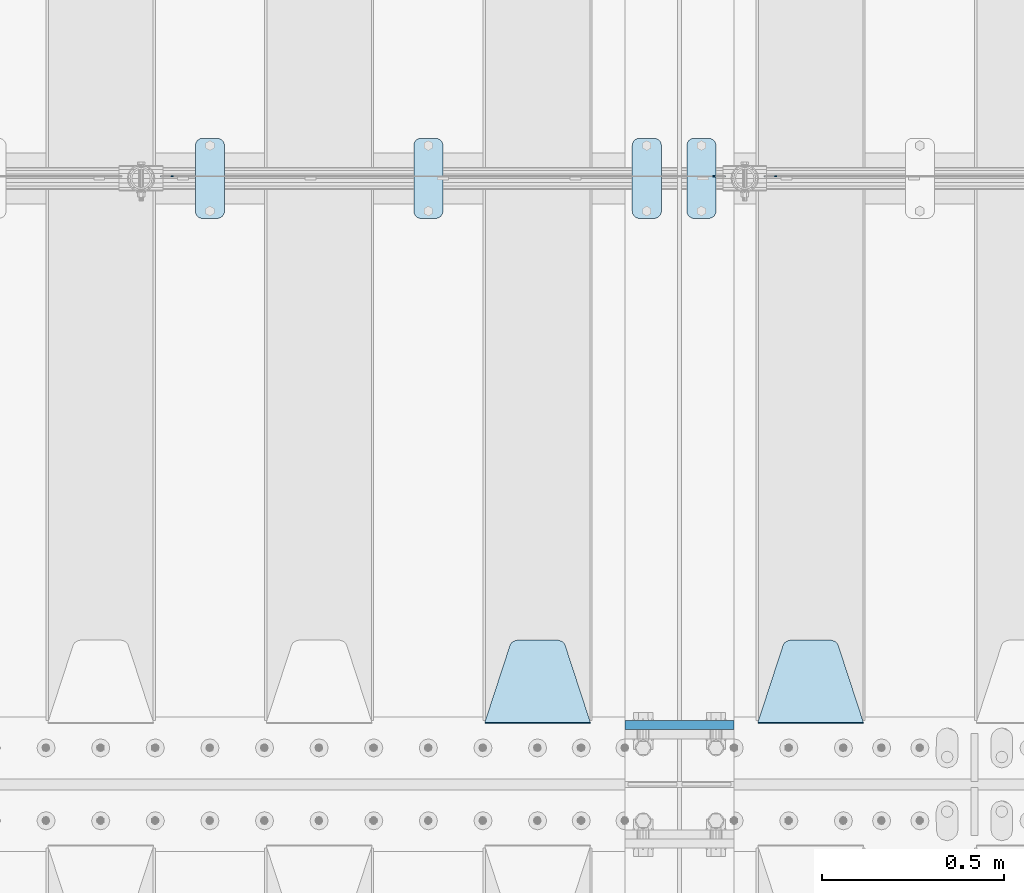
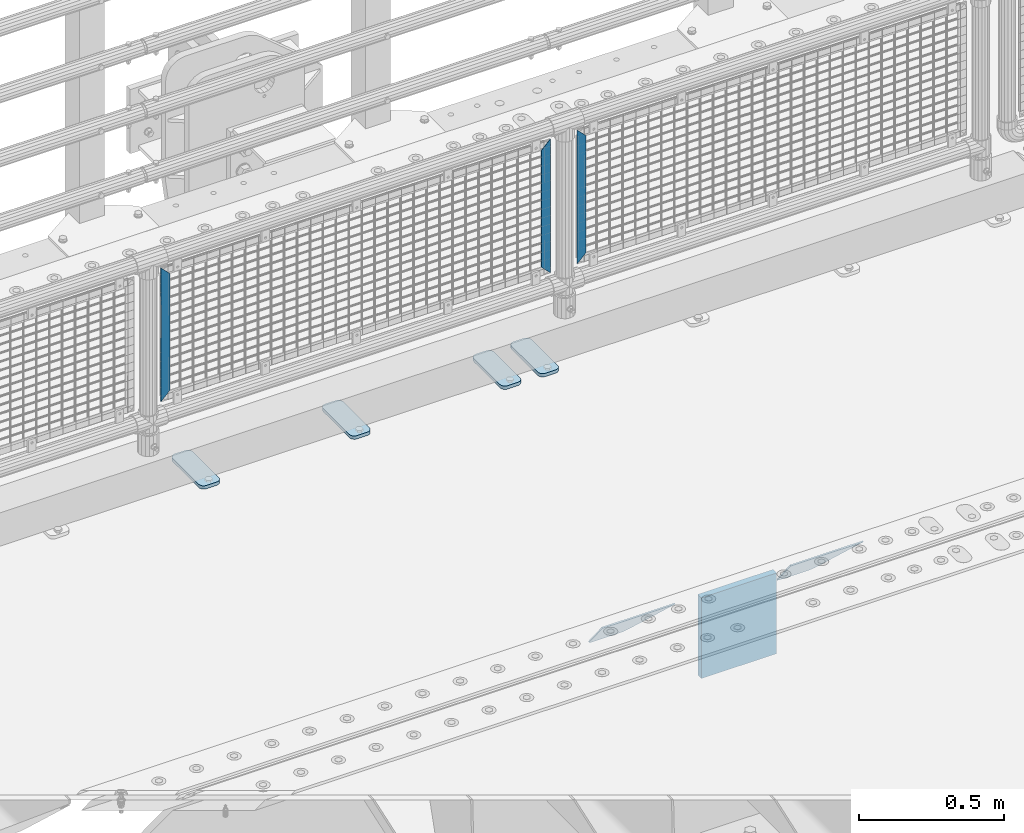
# One storey, part 219 of 240: 10 plates.
"""IFC2X3 building model written with IfcOpenShell, lengths in millimetres."""

from ifc_helpers import new_model, si_unit, frame, origin_with_axes, place, context, subcontext, project, spatial, faceted_brep, material, type_object, element, save


model = new_model("IFC2X3")

# Units and contexts
model_context = context("Model", 3, precision=1e-05, world=origin_with_axes())
body_context = subcontext(model_context, "Body", "Model", "MODEL_VIEW")
ifc_project = project(units=[si_unit("LENGTHUNIT", "METRE", prefix="MILLI"), si_unit("AREAUNIT", "SQUARE_METRE"), si_unit("VOLUMEUNIT", "CUBIC_METRE"), si_unit("MASSUNIT", "GRAM", prefix="KILO"), si_unit("TIMEUNIT", "SECOND"), si_unit("PLANEANGLEUNIT", "RADIAN"), si_unit("SOLIDANGLEUNIT", "STERADIAN"), si_unit("THERMODYNAMICTEMPERATUREUNIT", "DEGREE_CELSIUS"), si_unit("LUMINOUSINTENSITYUNIT", "LUMEN")], contexts=[model_context])

# Site, building, storey
site_placement = place(None, origin_with_axes())
site = spatial("IfcSite", under=ifc_project, at=site_placement, CompositionType="ELEMENT")
building_placement = place(site_placement, origin_with_axes())
building = spatial("IfcBuilding", under=site, at=building_placement, Name="Standard", CompositionType="ELEMENT")
storey_placement = place(building_placement, origin_with_axes())
storey = spatial("IfcBuildingStorey", under=building, at=storey_placement, Name="Undefined", CompositionType="ELEMENT", Elevation=0.0)

# Plates
ifc_material_1 = material(Name="STEEL/S355N")
plate_type_1 = type_object("IfcPlateType", PredefinedType="NOTDEFINED")
plate_1_placement = place(storey_placement, frame((52690.0, 33162.5, -340.000000000044), z_axis=(0.0, 0.0, 1.0), x_axis=(1.0, 0.0, 0.0)))
element("IfcPlate", 1, at=plate_1_placement, inside=storey, type_object=plate_type_1, material=ifc_material_1, context=body_context, shape_type="Brep", body=[
    faceted_brep([(0.0, -12.5, 0.0), (9.31322574615479e-10, -12.5, 340.0), (9.31322574615479e-10, 12.5, 340.0), (0.0, 12.5, 0.0), (300.0, -12.5, 340.0), (300.0, 12.5, 340.0), (300.0, -12.5, 0.0), (300.0, 12.5, 0.0)], [[[0, 1, 2, 3]], [[1, 4, 5, 2]], [[4, 6, 7, 5]], [[6, 0, 3, 7]], [[5, 7, 3, 2]], [[6, 4, 1, 0]]]),
])
plate_type_2 = type_object("IfcPlateType", PredefinedType="NOTDEFINED")
plate_2_placement = place(storey_placement, frame((53345.0, 33168.232233047, -1.76776695296758), z_axis=(0.0, 0.707106781186547, -0.707106781186548), x_axis=(-1.0, 0.0, 0.0)))
element("IfcPlate", 2, at=plate_2_placement, inside=storey, type_object=plate_type_2, material=ifc_material_1, context=body_context, shape_type="Brep", body=[
    faceted_brep([(0.0, -2.5, 0.0), (69.345504679477, -2.50000000000364, 300.171731424827), (69.345504679477, 2.49999999999636, 300.171731424827), (0.0, 2.5, 0.0), (70.927406119954, -2.50000000000364, 304.897442415397), (70.927406119954, 2.49999999999636, 304.897442415397), (73.3818627772271, -2.50000000000728, 309.234538108525), (73.3818627772271, 2.49999999999636, 309.234538108529), (76.6187032999587, -2.50000000000728, 313.023683126099), (76.6187032999587, 2.49999999999636, 313.023683126103), (80.5190132705029, -2.50000000000364, 316.125672595368), (80.5190132705029, 2.49999999999636, 316.125672595368), (84.9395038596849, -2.50000000000364, 318.426546230472), (84.9395038596849, 2.49999999999636, 318.426546230472), (89.7177759439219, -2.5, 319.841774983277), (89.7177759439219, 2.49999999999636, 319.841774983273), (94.6782862926484, -2.50000000000364, 320.319366455074), (94.6782862926484, 2.49999999999636, 320.319366455074), (195.321713707352, -2.50000000000364, 320.319366455074), (195.321713707352, 2.49999999999636, 320.319366455074), (200.282224056078, -2.50000000000364, 319.841774983273), (200.282224056078, 2.49999999999636, 319.841774983273), (205.060496140315, -2.50000000000364, 318.426546230472), (205.060496140315, 2.49999999999636, 318.426546230472), (209.480986729497, -2.50000000000364, 316.125672595368), (209.480986729497, 2.49999999999636, 316.125672595368), (213.381296700041, -2.50000000000728, 313.023683126099), (213.381296700041, 2.49999999999272, 313.023683126099), (216.618137222766, -2.50000000000364, 309.234538108522), (216.618137222766, 2.49999999999636, 309.234538108522), (219.072593880039, -2.50000000000364, 304.897442415397), (219.072593880039, 2.49999999999636, 304.897442415397), (220.654495320523, -2.50000000000364, 300.171731424827), (220.654495320523, 2.49999999999636, 300.171731424827), (290.0, -2.50000000000364, -3.63797880709171e-12), (290.0, 2.49999999999636, -3.63797880709171e-12)], [[[0, 1, 2, 3]], [[1, 4, 5, 2]], [[4, 6, 7, 5]], [[6, 8, 9, 7]], [[8, 10, 11, 9]], [[10, 12, 13, 11]], [[12, 14, 15, 13]], [[14, 16, 17, 15]], [[16, 18, 19, 17]], [[18, 20, 21, 19]], [[20, 22, 23, 21]], [[22, 24, 25, 23]], [[24, 26, 27, 25]], [[26, 28, 29, 27]], [[28, 30, 31, 29]], [[30, 32, 33, 31]], [[32, 34, 35, 33]], [[34, 0, 3, 35]], [[5, 7, 9, 11, 13, 15, 17, 19, 21, 23, 25, 27, 29, 31, 33, 35, 3, 2]], [[34, 32, 30, 28, 26, 24, 22, 20, 18, 16, 14, 12, 10, 8, 6, 4, 1, 0]]]),
])
plate_3_placement = place(storey_placement, frame((52595.0, 33168.232233047, -1.76776695296758), z_axis=(0.0, 0.707106781186547, -0.707106781186548), x_axis=(-1.0, 0.0, 0.0)))
element("IfcPlate", 3, at=plate_3_placement, inside=storey, type_object=plate_type_2, material=ifc_material_1, context=body_context, shape_type="Brep", body=[
    faceted_brep([(0.0, -2.5, 0.0), (69.345504679477, -2.50000000000364, 300.171731424827), (69.345504679477, 2.49999999999636, 300.171731424827), (0.0, 2.5, 0.0), (70.927406119954, -2.50000000000364, 304.897442415397), (70.927406119954, 2.49999999999636, 304.897442415397), (73.3818627772271, -2.50000000000728, 309.234538108525), (73.3818627772271, 2.49999999999636, 309.234538108529), (76.6187032999587, -2.50000000000728, 313.023683126099), (76.6187032999587, 2.49999999999636, 313.023683126103), (80.5190132705029, -2.50000000000364, 316.125672595368), (80.5190132705029, 2.49999999999636, 316.125672595368), (84.9395038596849, -2.50000000000364, 318.426546230472), (84.9395038596849, 2.49999999999636, 318.426546230472), (89.7177759439219, -2.5, 319.841774983277), (89.7177759439219, 2.49999999999636, 319.841774983273), (94.6782862926484, -2.50000000000364, 320.319366455074), (94.6782862926484, 2.49999999999636, 320.319366455074), (195.321713707352, -2.50000000000364, 320.319366455074), (195.321713707352, 2.49999999999636, 320.319366455074), (200.282224056078, -2.50000000000364, 319.841774983273), (200.282224056078, 2.49999999999636, 319.841774983273), (205.060496140315, -2.50000000000364, 318.426546230472), (205.060496140315, 2.49999999999636, 318.426546230472), (209.480986729497, -2.50000000000364, 316.125672595368), (209.480986729497, 2.49999999999636, 316.125672595368), (213.381296700041, -2.50000000000728, 313.023683126099), (213.381296700041, 2.49999999999272, 313.023683126099), (216.618137222766, -2.50000000000364, 309.234538108522), (216.618137222766, 2.49999999999636, 309.234538108522), (219.072593880039, -2.50000000000364, 304.897442415397), (219.072593880039, 2.49999999999636, 304.897442415397), (220.654495320523, -2.50000000000364, 300.171731424827), (220.654495320523, 2.49999999999636, 300.171731424827), (290.0, -2.50000000000364, -3.63797880709171e-12), (290.0, 2.49999999999636, -3.63797880709171e-12)], [[[0, 1, 2, 3]], [[1, 4, 5, 2]], [[4, 6, 7, 5]], [[6, 8, 9, 7]], [[8, 10, 11, 9]], [[10, 12, 13, 11]], [[12, 14, 15, 13]], [[14, 16, 17, 15]], [[16, 18, 19, 17]], [[18, 20, 21, 19]], [[20, 22, 23, 21]], [[22, 24, 25, 23]], [[24, 26, 27, 25]], [[26, 28, 29, 27]], [[28, 30, 31, 29]], [[30, 32, 33, 31]], [[32, 34, 35, 33]], [[34, 0, 3, 35]], [[5, 7, 9, 11, 13, 15, 17, 19, 21, 23, 25, 27, 29, 31, 33, 35, 3, 2]], [[34, 32, 30, 28, 26, 24, 22, 20, 18, 16, 14, 12, 10, 8, 6, 4, 1, 0]]]),
])
ifc_material_2 = material(Name="STEEL/S355J2")
plate_type_3 = type_object("IfcPlateType", PredefinedType="NOTDEFINED")
plate_4_placement = place(storey_placement, frame((52710.0, 34774.5, 21.0199999999977), z_axis=(1.0, 0.0, 0.0), x_axis=(0.0, -1.0, 0.0)))
element("IfcPlate", 4, at=plate_4_placement, inside=storey, type_object=plate_type_3, material=ifc_material_2, context=body_context, shape_type="Brep", body=[
    faceted_brep([(0.0, -7.0, 20.0), (0.0, -7.0, 60.0), (0.0, 7.0, 60.0), (0.0, 7.0, 20.0), (0.384294391937146, -7.0, 63.9018064403208), (0.384294391937146, 7.0, 63.9018064403208), (1.52240934977453, -7.0, 67.6536686473046), (1.52240934977453, 7.0, 67.6536686473046), (3.37060775394639, -7.0, 71.1114046603907), (3.37060775394639, 7.0, 71.1114046603907), (5.85786437626666, -7.0, 74.1421356237333), (5.85786437626666, 7.0, 74.1421356237333), (8.88859533960931, -7.0, 76.6293922460536), (8.88859533960931, 7.0, 76.6293922460536), (12.3463313526954, -7.0, 78.4775906502255), (12.3463313526954, 7.0, 78.4775906502255), (16.0981935596792, -7.0, 79.6157056080629), (16.0981935596792, 7.0, 79.6157056080629), (20.0, -7.0, 80.0), (20.0, 7.0, 80.0), (200.0, -7.0, 80.0), (200.0, 7.0, 80.0), (203.901806440321, -7.0, 79.6157056080629), (203.901806440321, 7.0, 79.6157056080629), (207.653668647305, -7.0, 78.4775906502255), (207.653668647305, 7.0, 78.4775906502255), (211.111404660391, -7.0, 76.6293922460536), (211.111404660391, 7.0, 76.6293922460536), (214.142135623733, -7.0, 74.1421356237333), (214.142135623733, 7.0, 74.1421356237333), (216.629392246054, -7.0, 71.1114046603907), (216.629392246054, 7.0, 71.1114046603907), (218.477590650225, -7.0, 67.6536686473046), (218.477590650225, 7.0, 67.6536686473046), (219.615705608063, -7.0, 63.9018064403208), (219.615705608063, 7.0, 63.9018064403208), (220.0, -7.0, 60.0), (220.0, 7.0, 60.0), (220.0, -7.0, 20.0), (220.0, 7.0, 20.0), (219.615705608063, -7.0, 16.0981935596792), (219.615705608063, 7.0, 16.0981935596792), (218.477590650225, -7.0, 12.3463313526954), (218.477590650225, 7.0, 12.3463313526954), (216.629392246054, -7.0, 8.88859533960931), (216.629392246054, 7.0, 8.88859533960931), (214.142135623733, -7.0, 5.85786437626666), (214.142135623733, 7.0, 5.85786437626666), (211.111404660391, -7.0, 3.37060775394639), (211.111404660391, 7.0, 3.37060775394639), (207.653668647305, -7.0, 1.52240934977453), (207.653668647305, 7.0, 1.52240934977453), (203.901806440321, -7.0, 0.384294391937146), (203.901806440321, 7.0, 0.384294391937146), (200.0, -7.0, 0.0), (200.0, 7.0, 0.0), (20.0, -7.0, 0.0), (20.0, 7.0, 0.0), (16.0981935596792, -7.0, 0.384294391937146), (16.0981935596792, 7.0, 0.384294391937146), (12.3463313526954, -7.0, 1.52240934977453), (12.3463313526954, 7.0, 1.52240934977453), (8.88859533960931, -7.0, 3.37060775394639), (8.88859533960931, 7.0, 3.37060775394639), (5.85786437626666, -7.0, 5.85786437626666), (5.85786437626666, 7.0, 5.85786437626666), (3.37060775394639, -7.0, 8.88859533960931), (3.37060775394639, 7.0, 8.88859533960931), (1.52240934977453, -7.0, 12.3463313526954), (1.52240934977453, 7.0, 12.3463313526954), (0.384294391937146, -7.0, 16.0981935596792), (0.384294391937146, 7.0, 16.0981935596792)], [[[0, 1, 2, 3]], [[1, 4, 5, 2]], [[4, 6, 7, 5]], [[6, 8, 9, 7]], [[8, 10, 11, 9]], [[10, 12, 13, 11]], [[12, 14, 15, 13]], [[14, 16, 17, 15]], [[16, 18, 19, 17]], [[18, 20, 21, 19]], [[20, 22, 23, 21]], [[22, 24, 25, 23]], [[24, 26, 27, 25]], [[26, 28, 29, 27]], [[28, 30, 31, 29]], [[30, 32, 33, 31]], [[32, 34, 35, 33]], [[34, 36, 37, 35]], [[36, 38, 39, 37]], [[38, 40, 41, 39]], [[40, 42, 43, 41]], [[42, 44, 45, 43]], [[44, 46, 47, 45]], [[46, 48, 49, 47]], [[48, 50, 51, 49]], [[50, 52, 53, 51]], [[52, 54, 55, 53]], [[54, 56, 57, 55]], [[56, 58, 59, 57]], [[58, 60, 61, 59]], [[60, 62, 63, 61]], [[62, 64, 65, 63]], [[64, 66, 67, 65]], [[66, 68, 69, 67]], [[68, 70, 71, 69]], [[70, 0, 3, 71]], [[5, 7, 9, 11, 13, 15, 17, 19, 21, 23, 25, 27, 29, 31, 33, 35, 37, 39, 41, 43, 45, 47, 49, 51, 53, 55, 57, 59, 61, 63, 65, 67, 69, 71, 3, 2]], [[70, 68, 66, 64, 62, 60, 58, 56, 54, 52, 50, 48, 46, 44, 42, 40, 38, 36, 34, 32, 30, 28, 26, 24, 22, 20, 18, 16, 14, 12, 10, 8, 6, 4, 1, 0]]]),
])
plate_5_placement = place(storey_placement, frame((52860.0, 34774.5, 21.0199999999977), z_axis=(1.0, 0.0, 0.0), x_axis=(0.0, -1.0, 0.0)))
element("IfcPlate", 5, at=plate_5_placement, inside=storey, type_object=plate_type_3, material=ifc_material_2, context=body_context, shape_type="Brep", body=[
    faceted_brep([(0.0, -7.0, 20.0), (0.0, -7.0, 60.0), (0.0, 7.0, 60.0), (0.0, 7.0, 20.0), (0.384294391937146, -7.0, 63.9018064403208), (0.384294391937146, 7.0, 63.9018064403208), (1.52240934977453, -7.0, 67.6536686473046), (1.52240934977453, 7.0, 67.6536686473046), (3.37060775394639, -7.0, 71.1114046603907), (3.37060775394639, 7.0, 71.1114046603907), (5.85786437626666, -7.0, 74.1421356237333), (5.85786437626666, 7.0, 74.1421356237333), (8.88859533960931, -7.0, 76.6293922460536), (8.88859533960931, 7.0, 76.6293922460536), (12.3463313526954, -7.0, 78.4775906502255), (12.3463313526954, 7.0, 78.4775906502255), (16.0981935596792, -7.0, 79.6157056080629), (16.0981935596792, 7.0, 79.6157056080629), (20.0, -7.0, 80.0), (20.0, 7.0, 80.0), (200.0, -7.0, 80.0), (200.0, 7.0, 80.0), (203.901806440321, -7.0, 79.6157056080629), (203.901806440321, 7.0, 79.6157056080629), (207.653668647305, -7.0, 78.4775906502255), (207.653668647305, 7.0, 78.4775906502255), (211.111404660391, -7.0, 76.6293922460536), (211.111404660391, 7.0, 76.6293922460536), (214.142135623733, -7.0, 74.1421356237333), (214.142135623733, 7.0, 74.1421356237333), (216.629392246054, -7.0, 71.1114046603907), (216.629392246054, 7.0, 71.1114046603907), (218.477590650225, -7.0, 67.6536686473046), (218.477590650225, 7.0, 67.6536686473046), (219.615705608063, -7.0, 63.9018064403208), (219.615705608063, 7.0, 63.9018064403208), (220.0, -7.0, 60.0), (220.0, 7.0, 60.0), (220.0, -7.0, 20.0), (220.0, 7.0, 20.0), (219.615705608063, -7.0, 16.0981935596792), (219.615705608063, 7.0, 16.0981935596792), (218.477590650225, -7.0, 12.3463313526954), (218.477590650225, 7.0, 12.3463313526954), (216.629392246054, -7.0, 8.88859533960931), (216.629392246054, 7.0, 8.88859533960931), (214.142135623733, -7.0, 5.85786437626666), (214.142135623733, 7.0, 5.85786437626666), (211.111404660391, -7.0, 3.37060775394639), (211.111404660391, 7.0, 3.37060775394639), (207.653668647305, -7.0, 1.52240934977453), (207.653668647305, 7.0, 1.52240934977453), (203.901806440321, -7.0, 0.384294391937146), (203.901806440321, 7.0, 0.384294391937146), (200.0, -7.0, 0.0), (200.0, 7.0, 0.0), (20.0, -7.0, 0.0), (20.0, 7.0, 0.0), (16.0981935596792, -7.0, 0.384294391937146), (16.0981935596792, 7.0, 0.384294391937146), (12.3463313526954, -7.0, 1.52240934977453), (12.3463313526954, 7.0, 1.52240934977453), (8.88859533960931, -7.0, 3.37060775394639), (8.88859533960931, 7.0, 3.37060775394639), (5.85786437626666, -7.0, 5.85786437626666), (5.85786437626666, 7.0, 5.85786437626666), (3.37060775394639, -7.0, 8.88859533960931), (3.37060775394639, 7.0, 8.88859533960931), (1.52240934977453, -7.0, 12.3463313526954), (1.52240934977453, 7.0, 12.3463313526954), (0.384294391937146, -7.0, 16.0981935596792), (0.384294391937146, 7.0, 16.0981935596792)], [[[0, 1, 2, 3]], [[1, 4, 5, 2]], [[4, 6, 7, 5]], [[6, 8, 9, 7]], [[8, 10, 11, 9]], [[10, 12, 13, 11]], [[12, 14, 15, 13]], [[14, 16, 17, 15]], [[16, 18, 19, 17]], [[18, 20, 21, 19]], [[20, 22, 23, 21]], [[22, 24, 25, 23]], [[24, 26, 27, 25]], [[26, 28, 29, 27]], [[28, 30, 31, 29]], [[30, 32, 33, 31]], [[32, 34, 35, 33]], [[34, 36, 37, 35]], [[36, 38, 39, 37]], [[38, 40, 41, 39]], [[40, 42, 43, 41]], [[42, 44, 45, 43]], [[44, 46, 47, 45]], [[46, 48, 49, 47]], [[48, 50, 51, 49]], [[50, 52, 53, 51]], [[52, 54, 55, 53]], [[54, 56, 57, 55]], [[56, 58, 59, 57]], [[58, 60, 61, 59]], [[60, 62, 63, 61]], [[62, 64, 65, 63]], [[64, 66, 67, 65]], [[66, 68, 69, 67]], [[68, 70, 71, 69]], [[70, 0, 3, 71]], [[5, 7, 9, 11, 13, 15, 17, 19, 21, 23, 25, 27, 29, 31, 33, 35, 37, 39, 41, 43, 45, 47, 49, 51, 53, 55, 57, 59, 61, 63, 65, 67, 69, 71, 3, 2]], [[70, 68, 66, 64, 62, 60, 58, 56, 54, 52, 50, 48, 46, 44, 42, 40, 38, 36, 34, 32, 30, 28, 26, 24, 22, 20, 18, 16, 14, 12, 10, 8, 6, 4, 1, 0]]]),
])
plate_6_placement = place(storey_placement, frame((52110.0, 34774.5, 21.0199999999977), z_axis=(1.0, 0.0, 0.0), x_axis=(0.0, -1.0, 0.0)))
element("IfcPlate", 6, at=plate_6_placement, inside=storey, type_object=plate_type_3, material=ifc_material_2, context=body_context, shape_type="Brep", body=[
    faceted_brep([(0.0, -7.0, 20.0), (0.0, -7.0, 60.0), (0.0, 7.0, 60.0), (0.0, 7.0, 20.0), (0.384294391937146, -7.0, 63.9018064403208), (0.384294391937146, 7.0, 63.9018064403208), (1.52240934977453, -7.0, 67.6536686473046), (1.52240934977453, 7.0, 67.6536686473046), (3.37060775394639, -7.0, 71.1114046603907), (3.37060775394639, 7.0, 71.1114046603907), (5.85786437626666, -7.0, 74.1421356237333), (5.85786437626666, 7.0, 74.1421356237333), (8.88859533960931, -7.0, 76.6293922460536), (8.88859533960931, 7.0, 76.6293922460536), (12.3463313526954, -7.0, 78.4775906502255), (12.3463313526954, 7.0, 78.4775906502255), (16.0981935596792, -7.0, 79.6157056080629), (16.0981935596792, 7.0, 79.6157056080629), (20.0, -7.0, 80.0), (20.0, 7.0, 80.0), (200.0, -7.0, 80.0), (200.0, 7.0, 80.0), (203.901806440321, -7.0, 79.6157056080629), (203.901806440321, 7.0, 79.6157056080629), (207.653668647305, -7.0, 78.4775906502255), (207.653668647305, 7.0, 78.4775906502255), (211.111404660391, -7.0, 76.6293922460536), (211.111404660391, 7.0, 76.6293922460536), (214.142135623733, -7.0, 74.1421356237333), (214.142135623733, 7.0, 74.1421356237333), (216.629392246054, -7.0, 71.1114046603907), (216.629392246054, 7.0, 71.1114046603907), (218.477590650225, -7.0, 67.6536686473046), (218.477590650225, 7.0, 67.6536686473046), (219.615705608063, -7.0, 63.9018064403208), (219.615705608063, 7.0, 63.9018064403208), (220.0, -7.0, 60.0), (220.0, 7.0, 60.0), (220.0, -7.0, 20.0), (220.0, 7.0, 20.0), (219.615705608063, -7.0, 16.0981935596792), (219.615705608063, 7.0, 16.0981935596792), (218.477590650225, -7.0, 12.3463313526954), (218.477590650225, 7.0, 12.3463313526954), (216.629392246054, -7.0, 8.88859533960931), (216.629392246054, 7.0, 8.88859533960931), (214.142135623733, -7.0, 5.85786437626666), (214.142135623733, 7.0, 5.85786437626666), (211.111404660391, -7.0, 3.37060775394639), (211.111404660391, 7.0, 3.37060775394639), (207.653668647305, -7.0, 1.52240934977453), (207.653668647305, 7.0, 1.52240934977453), (203.901806440321, -7.0, 0.384294391937146), (203.901806440321, 7.0, 0.384294391937146), (200.0, -7.0, 0.0), (200.0, 7.0, 0.0), (20.0, -7.0, 0.0), (20.0, 7.0, 0.0), (16.0981935596792, -7.0, 0.384294391937146), (16.0981935596792, 7.0, 0.384294391937146), (12.3463313526954, -7.0, 1.52240934977453), (12.3463313526954, 7.0, 1.52240934977453), (8.88859533960931, -7.0, 3.37060775394639), (8.88859533960931, 7.0, 3.37060775394639), (5.85786437626666, -7.0, 5.85786437626666), (5.85786437626666, 7.0, 5.85786437626666), (3.37060775394639, -7.0, 8.88859533960931), (3.37060775394639, 7.0, 8.88859533960931), (1.52240934977453, -7.0, 12.3463313526954), (1.52240934977453, 7.0, 12.3463313526954), (0.384294391937146, -7.0, 16.0981935596792), (0.384294391937146, 7.0, 16.0981935596792)], [[[0, 1, 2, 3]], [[1, 4, 5, 2]], [[4, 6, 7, 5]], [[6, 8, 9, 7]], [[8, 10, 11, 9]], [[10, 12, 13, 11]], [[12, 14, 15, 13]], [[14, 16, 17, 15]], [[16, 18, 19, 17]], [[18, 20, 21, 19]], [[20, 22, 23, 21]], [[22, 24, 25, 23]], [[24, 26, 27, 25]], [[26, 28, 29, 27]], [[28, 30, 31, 29]], [[30, 32, 33, 31]], [[32, 34, 35, 33]], [[34, 36, 37, 35]], [[36, 38, 39, 37]], [[38, 40, 41, 39]], [[40, 42, 43, 41]], [[42, 44, 45, 43]], [[44, 46, 47, 45]], [[46, 48, 49, 47]], [[48, 50, 51, 49]], [[50, 52, 53, 51]], [[52, 54, 55, 53]], [[54, 56, 57, 55]], [[56, 58, 59, 57]], [[58, 60, 61, 59]], [[60, 62, 63, 61]], [[62, 64, 65, 63]], [[64, 66, 67, 65]], [[66, 68, 69, 67]], [[68, 70, 71, 69]], [[70, 0, 3, 71]], [[5, 7, 9, 11, 13, 15, 17, 19, 21, 23, 25, 27, 29, 31, 33, 35, 37, 39, 41, 43, 45, 47, 49, 51, 53, 55, 57, 59, 61, 63, 65, 67, 69, 71, 3, 2]], [[70, 68, 66, 64, 62, 60, 58, 56, 54, 52, 50, 48, 46, 44, 42, 40, 38, 36, 34, 32, 30, 28, 26, 24, 22, 20, 18, 16, 14, 12, 10, 8, 6, 4, 1, 0]]]),
])
plate_7_placement = place(storey_placement, frame((51510.0, 34774.5, 21.0199999999977), z_axis=(1.0, 0.0, 0.0), x_axis=(0.0, -1.0, 0.0)))
element("IfcPlate", 7, at=plate_7_placement, inside=storey, type_object=plate_type_3, material=ifc_material_2, context=body_context, shape_type="Brep", body=[
    faceted_brep([(0.0, -7.0, 20.0), (0.0, -7.0, 60.0), (0.0, 7.0, 60.0), (0.0, 7.0, 20.0), (0.384294391937146, -7.0, 63.9018064403208), (0.384294391937146, 7.0, 63.9018064403208), (1.52240934977453, -7.0, 67.6536686473046), (1.52240934977453, 7.0, 67.6536686473046), (3.37060775394639, -7.0, 71.1114046603907), (3.37060775394639, 7.0, 71.1114046603907), (5.85786437626666, -7.0, 74.1421356237333), (5.85786437626666, 7.0, 74.1421356237333), (8.88859533960931, -7.0, 76.6293922460536), (8.88859533960931, 7.0, 76.6293922460536), (12.3463313526954, -7.0, 78.4775906502255), (12.3463313526954, 7.0, 78.4775906502255), (16.0981935596792, -7.0, 79.6157056080629), (16.0981935596792, 7.0, 79.6157056080629), (20.0, -7.0, 80.0), (20.0, 7.0, 80.0), (200.0, -7.0, 80.0), (200.0, 7.0, 80.0), (203.901806440321, -7.0, 79.6157056080629), (203.901806440321, 7.0, 79.6157056080629), (207.653668647305, -7.0, 78.4775906502255), (207.653668647305, 7.0, 78.4775906502255), (211.111404660391, -7.0, 76.6293922460536), (211.111404660391, 7.0, 76.6293922460536), (214.142135623733, -7.0, 74.1421356237333), (214.142135623733, 7.0, 74.1421356237333), (216.629392246054, -7.0, 71.1114046603907), (216.629392246054, 7.0, 71.1114046603907), (218.477590650225, -7.0, 67.6536686473046), (218.477590650225, 7.0, 67.6536686473046), (219.615705608063, -7.0, 63.9018064403208), (219.615705608063, 7.0, 63.9018064403208), (220.0, -7.0, 60.0), (220.0, 7.0, 60.0), (220.0, -7.0, 20.0), (220.0, 7.0, 20.0), (219.615705608063, -7.0, 16.0981935596792), (219.615705608063, 7.0, 16.0981935596792), (218.477590650225, -7.0, 12.3463313526954), (218.477590650225, 7.0, 12.3463313526954), (216.629392246054, -7.0, 8.88859533960931), (216.629392246054, 7.0, 8.88859533960931), (214.142135623733, -7.0, 5.85786437626666), (214.142135623733, 7.0, 5.85786437626666), (211.111404660391, -7.0, 3.37060775394639), (211.111404660391, 7.0, 3.37060775394639), (207.653668647305, -7.0, 1.52240934977453), (207.653668647305, 7.0, 1.52240934977453), (203.901806440321, -7.0, 0.384294391937146), (203.901806440321, 7.0, 0.384294391937146), (200.0, -7.0, 0.0), (200.0, 7.0, 0.0), (20.0, -7.0, 0.0), (20.0, 7.0, 0.0), (16.0981935596792, -7.0, 0.384294391937146), (16.0981935596792, 7.0, 0.384294391937146), (12.3463313526954, -7.0, 1.52240934977453), (12.3463313526954, 7.0, 1.52240934977453), (8.88859533960931, -7.0, 3.37060775394639), (8.88859533960931, 7.0, 3.37060775394639), (5.85786437626666, -7.0, 5.85786437626666), (5.85786437626666, 7.0, 5.85786437626666), (3.37060775394639, -7.0, 8.88859533960931), (3.37060775394639, 7.0, 8.88859533960931), (1.52240934977453, -7.0, 12.3463313526954), (1.52240934977453, 7.0, 12.3463313526954), (0.384294391937146, -7.0, 16.0981935596792), (0.384294391937146, 7.0, 16.0981935596792)], [[[0, 1, 2, 3]], [[1, 4, 5, 2]], [[4, 6, 7, 5]], [[6, 8, 9, 7]], [[8, 10, 11, 9]], [[10, 12, 13, 11]], [[12, 14, 15, 13]], [[14, 16, 17, 15]], [[16, 18, 19, 17]], [[18, 20, 21, 19]], [[20, 22, 23, 21]], [[22, 24, 25, 23]], [[24, 26, 27, 25]], [[26, 28, 29, 27]], [[28, 30, 31, 29]], [[30, 32, 33, 31]], [[32, 34, 35, 33]], [[34, 36, 37, 35]], [[36, 38, 39, 37]], [[38, 40, 41, 39]], [[40, 42, 43, 41]], [[42, 44, 45, 43]], [[44, 46, 47, 45]], [[46, 48, 49, 47]], [[48, 50, 51, 49]], [[50, 52, 53, 51]], [[52, 54, 55, 53]], [[54, 56, 57, 55]], [[56, 58, 59, 57]], [[58, 60, 61, 59]], [[60, 62, 63, 61]], [[62, 64, 65, 63]], [[64, 66, 67, 65]], [[66, 68, 69, 67]], [[68, 70, 71, 69]], [[70, 0, 3, 71]], [[5, 7, 9, 11, 13, 15, 17, 19, 21, 23, 25, 27, 29, 31, 33, 35, 37, 39, 41, 43, 45, 47, 49, 51, 53, 55, 57, 59, 61, 63, 65, 67, 69, 71, 3, 2]], [[70, 68, 66, 64, 62, 60, 58, 56, 54, 52, 50, 48, 46, 44, 42, 40, 38, 36, 34, 32, 30, 28, 26, 24, 22, 20, 18, 16, 14, 12, 10, 8, 6, 4, 1, 0]]]),
])
ifc_material_3 = material(Name="Misc_Undefined")
plate_type_4 = type_object("IfcPlateType", PredefinedType="NOTDEFINED")
for number, where, z_axis, x_axis in (
    (8, (53107.509713541, 34670.5, 879.519963133601), (-0.707008801899317, 0.0, -0.707204746899292), (-0.707204746899293, 0.0, 0.707008801899317)),
    (9, (51449.509713541, 34670.5, 879.519963133601), (-0.707008801899317, 0.0, -0.707204746899292), (-0.707204746899293, 0.0, 0.707008801899317)),
):
    element("IfcPlate", number, at=place(storey_placement, frame(where, z_axis=z_axis, x_axis=x_axis)), inside=storey, type_object=plate_type_4, material=ifc_material_3, context=body_context, shape_type="Brep", body=[
        faceted_brep([(-7.27595761418343e-12, -1.49999999999272, 0.0), (-348.552185058594, -1.5, 348.65502929686), (-348.552185058594, 1.5, 348.65502929686), (0.0, 1.50000000000728, 0.0), (-348.544891357415, -1.5, 398.152496337883), (-348.544891357415, 1.5, 398.152496337883), (49.5043945312573, -1.5, 6.54836185276508e-11), (49.5043945312573, 1.5, 6.54836185276508e-11)], [[[0, 1, 2, 3]], [[1, 4, 5, 2]], [[4, 6, 7, 5]], [[6, 0, 3, 7]], [[5, 7, 3, 2]], [[6, 4, 1, 0]]]),
    ])
plate_8_placement = place(storey_placement, frame((52930.4996874836, 34670.5, 879.52), z_axis=(0.707103624179501, 0.0, -0.707109938179499), x_axis=(0.707109938179525, 0.0, 0.707103624179475)))
element("IfcPlate", 10, at=plate_8_placement, inside=storey, type_object=plate_type_4, material=ifc_material_3, context=body_context, shape_type="Brep", body=[
    faceted_brep([(-7.27595761418343e-12, -1.49999999999272, 0.0), (-348.605163574233, -1.5, 348.602081298821), (-348.605163574233, 1.5, 348.602081298821), (0.0, 1.50000000000728, 0.0), (-348.605163574226, -1.5, 398.099334716797), (-348.605163574226, 1.5, 398.099334716797), (49.4976959228443, -1.5, -1.09139364212751e-10), (49.4976959228443, 1.5, -1.09139364212751e-10)], [[[0, 1, 2, 3]], [[1, 4, 5, 2]], [[4, 6, 7, 5]], [[6, 0, 3, 7]], [[5, 7, 3, 2]], [[6, 4, 1, 0]]]),
])

save(model, "model.ifc")
